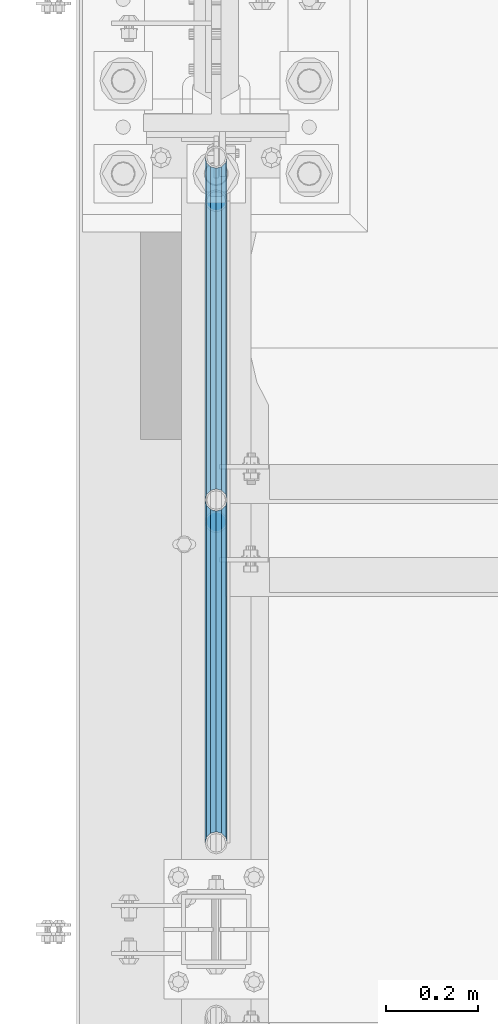
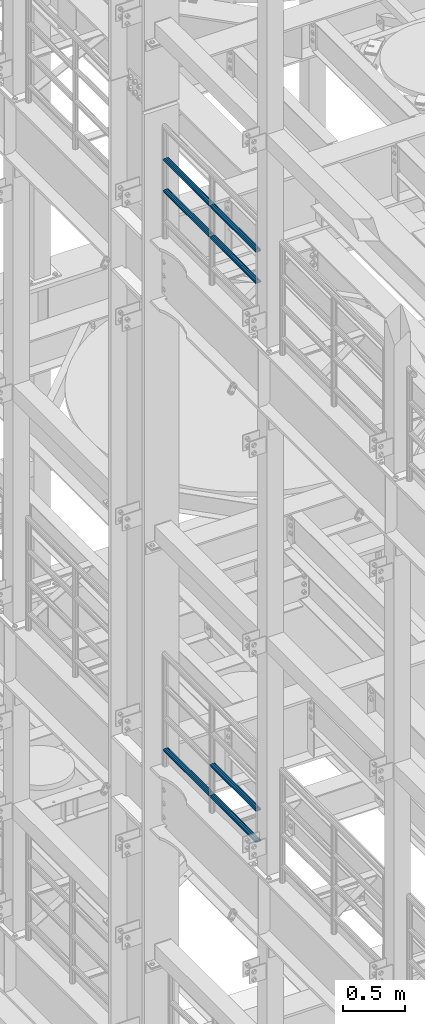
# One storey, part 1284 of 1876: 7 beams, 2 elements without a shape of their own.
"""IFC2X3 building model written with IfcOpenShell, lengths in millimetres."""

from ifc_helpers import new_model, si_unit, frame, origin_with_axes, place, context, subcontext, project, spatial, faceted_brep, material, type_object, element, aggregate, save


model = new_model("IFC2X3")

# Units and contexts
model_context = context("Model", 3, precision=1e-05, world=origin_with_axes())
body_context = subcontext(model_context, "Body", "Model", "MODEL_VIEW")
ifc_project = project(units=[si_unit("LENGTHUNIT", "METRE", prefix="MILLI"), si_unit("AREAUNIT", "SQUARE_METRE"), si_unit("VOLUMEUNIT", "CUBIC_METRE"), si_unit("MASSUNIT", "GRAM", prefix="KILO"), si_unit("TIMEUNIT", "SECOND"), si_unit("PLANEANGLEUNIT", "RADIAN"), si_unit("SOLIDANGLEUNIT", "STERADIAN"), si_unit("THERMODYNAMICTEMPERATUREUNIT", "DEGREE_CELSIUS"), si_unit("LUMINOUSINTENSITYUNIT", "LUMEN")], contexts=[model_context])

# Site, building, storey
site_placement = place(None, origin_with_axes())
site = spatial("IfcSite", under=ifc_project, at=site_placement, CompositionType="ELEMENT")
building_placement = place(site_placement, origin_with_axes())
building = spatial("IfcBuilding", under=site, at=building_placement, Name="Undefined", CompositionType="ELEMENT")
storey_placement = place(building_placement, origin_with_axes())
storey = spatial("IfcBuildingStorey", under=building, at=storey_placement, Name="Undefined", CompositionType="ELEMENT", Elevation=0.0)

# Assembly, beams
assembly_1_placement = place(storey_placement, origin_with_axes())
assembly_1 = element("IfcElementAssembly", 1, at=assembly_1_placement, inside=storey, Name="RAIL", AssemblyPlace="NOTDEFINED", PredefinedType="RIGID_FRAME")
ifc_material = material()
beam_type = type_object("IfcBeamType", Name="PIPE1-1/2SCH40", PredefinedType="NOTDEFINED")
beam_1_placement = place(assembly_1_placement, frame((-1.81898940354586e-12, 5777.23, 13776.325), z_axis=(0.0, 0.0, -1.0), x_axis=(0.0, 1.0, 0.0)))
beam_1 = element("IfcBeam", 2, at=beam_1_placement, type_object=beam_type, material=ifc_material, Name="RAIL", ObjectType="PIPE1-1/2SCH40", context=body_context, shape_type="Brep", body=[
    faceted_brep([(0.0, 24.1299999999992, 0.0), (12.0650000000064, 20.8971929933177, -12.0649999999987), (12.0650000000064, 20.8971929933177, 12.0649999999987), (12.0650000000064, -20.8971929933177, 12.0649999999987), (12.0650000000064, -20.8971929933177, -12.0649999999987), (0.0, -24.1299999999992, 0.0), (20.8971929933249, -12.0650000000005, 20.8971929933177), (20.8971929933249, -12.0650000000005, 15.8661214311796), (15.2545715621445, -17.7076214311801, 10.2235000000001), (12.5151929933249, -20.4470000000001, 0.0), (15.2545715621445, -17.7076214311801, -10.2235000000001), (20.8971929933249, -12.0650000000005, -15.8661214311796), (20.8971929933249, -12.0650000000005, -20.8971929933177), (24.1300000000063, 0.0, -20.4470000000001), (24.1300000000063, 0.0, -24.130000000001), (21.3906214311868, -10.2235000000001, -17.7076214311819), (21.3906214311868, 10.2235000000001, -17.7076214311819), (20.8971929933249, 12.0650000000005, -15.8661214311796), (20.8971929933249, 12.0650000000005, -20.8971929933177), (15.2545715621445, 17.7076214311801, -10.2235000000001), (12.5151929933249, 20.4470000000001, 0.0), (15.2545715621445, 17.7076214311801, 10.2235000000001), (20.8971929933249, 12.0650000000005, 15.8661214311796), (20.8971929933249, 12.0650000000005, 20.8971929933177), (21.3906214311868, 10.2235000000001, 17.7076214311819), (24.1300000000064, 0.0, 20.4470000000001), (24.1300000000064, 0.0, 24.130000000001), (21.3906214311868, -10.2235000000001, 17.7076214311819), (748.982500000002, 24.1300000000001, 0.0), (736.917500000002, 20.8971929933186, -12.0649999999987), (728.085307006683, 12.0649999999996, -20.8971929933177), (748.982500000002, -24.1300000000001, 0.0), (736.917500000002, -20.8971929933186, -12.0649999999987), (736.917500000002, -20.8971929933186, 12.0649999999987), (728.085307006683, -12.0649999999996, 20.8971929933177), (728.085307006683, -12.0649999999996, -20.8971929933177), (724.852500000002, 0.0, -24.130000000001), (727.591878568821, 10.2235000000001, -17.7076214311819), (724.852500000002, 0.0, -20.4470000000001), (728.085307006683, 12.0649999999996, -15.8661214311796), (728.085307006683, -12.0649999999996, -15.8661214311796), (727.591878568821, -10.2235000000001, -17.7076214311819), (733.727928437864, -17.7076214311801, -10.2235000000001), (736.467307006683, -20.4470000000001, 0.0), (733.727928437864, -17.7076214311801, 10.2235000000001), (728.085307006683, -12.0649999999996, 15.8661214311796), (727.591878568821, -10.2235000000001, 17.7076214311819), (724.852500000002, 0.0, 20.4470000000001), (724.852500000002, 0.0, 24.130000000001), (728.085307006683, 12.0649999999996, 20.8971929933177), (736.917500000002, 20.8971929933186, 12.0649999999987), (728.085307006683, 12.0649999999996, 15.8661214311796), (733.727928437864, 17.7076214311801, 10.2235000000001), (736.467307006683, 20.4470000000001, 0.0), (733.727928437864, 17.7076214311801, -10.2235000000001), (727.591878568821, 10.2235000000001, 17.7076214311819)], [[[0, 1, 2]], [[3, 4, 5]], [[6, 7, 8, 9, 10, 11, 12, 4, 3]], [[13, 14, 12, 11, 15]], [[16, 17, 18, 14, 13]], [[2, 1, 18, 17, 19, 20, 21, 22, 23]], [[23, 22, 24, 25, 26]], [[26, 25, 27, 7, 6]], [[1, 0, 28, 29]], [[18, 1, 29, 30]], [[31, 32, 33]], [[6, 3, 33, 34]], [[3, 5, 31, 33]], [[5, 4, 32, 31]], [[4, 12, 35, 32]], [[12, 14, 36, 35]], [[14, 18, 30, 36]], [[37, 38, 36, 30, 39]], [[40, 35, 36, 38, 41]], [[33, 32, 35, 40, 42, 43, 44, 45, 34]], [[34, 45, 46, 47, 48]], [[26, 6, 34, 48]], [[2, 23, 49, 50]], [[23, 26, 48, 49]], [[0, 2, 50, 28]], [[28, 50, 29]], [[49, 51, 52, 53, 54, 39, 30, 29, 50]], [[48, 47, 55, 51, 49]], [[25, 24, 55, 47]], [[55, 24, 22, 21, 52, 51]], [[21, 20, 53, 52]], [[20, 19, 54, 53]], [[19, 17, 16, 37, 39, 54]], [[16, 13, 38, 37]], [[13, 15, 41, 38]], [[41, 15, 11, 10, 42, 40]], [[10, 9, 43, 42]], [[9, 8, 44, 43]], [[8, 7, 27, 46, 45, 44]], [[27, 25, 47, 46]]]),
])
beam_2_placement = place(assembly_1_placement, frame((-1.81898940354586e-12, 6526.2125, 13776.325), z_axis=(0.0, 0.0, -1.0), x_axis=(0.0, 1.0, 0.0)))
beam_2 = element("IfcBeam", 3, at=beam_2_placement, type_object=beam_type, material=ifc_material, Name="RAIL", ObjectType="PIPE1-1/2SCH40", context=body_context, shape_type="Brep", body=[
    faceted_brep([(0.0, 24.1299999999992, 0.0), (12.0650000000064, 20.8971929933177, -12.0649999999987), (12.0650000000064, 20.8971929933177, 12.0649999999987), (12.0650000000064, -20.8971929933177, 12.0649999999987), (12.0650000000064, -20.8971929933177, -12.0649999999987), (0.0, -24.1299999999992, 0.0), (20.8971929933249, -12.0650000000005, 20.8971929933177), (20.8971929933249, -12.0650000000005, 15.8661214311796), (15.2545715621445, -17.7076214311801, 10.2235000000001), (12.5151929933249, -20.4470000000001, 0.0), (15.2545715621445, -17.7076214311801, -10.2235000000001), (20.8971929933249, -12.0650000000005, -15.8661214311796), (20.8971929933249, -12.0650000000005, -20.8971929933177), (24.1300000000063, 0.0, -20.4470000000001), (24.1300000000063, 0.0, -24.130000000001), (21.3906214311868, -10.2235000000001, -17.7076214311819), (21.3906214311868, 10.2235000000001, -17.7076214311819), (20.8971929933249, 12.0650000000005, -15.8661214311796), (20.8971929933249, 12.0650000000005, -20.8971929933177), (15.2545715621445, 17.7076214311801, -10.2235000000001), (12.5151929933249, 20.4470000000001, 0.0), (15.2545715621445, 17.7076214311801, 10.2235000000001), (20.8971929933249, 12.0650000000005, 15.8661214311796), (20.8971929933249, 12.0650000000005, 20.8971929933177), (21.3906214311868, 10.2235000000001, 17.7076214311819), (24.1300000000064, 0.0, 20.4470000000001), (24.1300000000064, 0.0, 24.130000000001), (21.3906214311868, -10.2235000000001, 17.7076214311819), (748.982500000002, 24.1300000000001, 0.0), (736.917500000002, 20.8971929933186, -12.0649999999987), (728.085307006683, 12.0649999999996, -20.8971929933177), (748.982500000002, -24.1300000000001, 0.0), (736.917500000002, -20.8971929933186, -12.0649999999987), (736.917500000002, -20.8971929933186, 12.0649999999987), (728.085307006683, -12.0649999999996, 20.8971929933177), (728.085307006683, -12.0649999999996, -20.8971929933177), (724.852500000002, 0.0, -24.130000000001), (727.591878568821, 10.2235000000001, -17.7076214311819), (724.852500000002, 0.0, -20.4470000000001), (728.085307006683, 12.0649999999996, -15.8661214311796), (728.085307006683, -12.0649999999996, -15.8661214311796), (727.591878568821, -10.2235000000001, -17.7076214311819), (733.727928437864, -17.7076214311801, -10.2235000000001), (736.467307006683, -20.4470000000001, 0.0), (733.727928437864, -17.7076214311801, 10.2235000000001), (728.085307006683, -12.0649999999996, 15.8661214311796), (727.591878568821, -10.2235000000001, 17.7076214311819), (724.852500000002, 0.0, 20.4470000000001), (724.852500000002, 0.0, 24.130000000001), (728.085307006683, 12.0649999999996, 20.8971929933177), (736.917500000002, 20.8971929933186, 12.0649999999987), (728.085307006683, 12.0649999999996, 15.8661214311796), (733.727928437864, 17.7076214311801, 10.2235000000001), (736.467307006683, 20.4470000000001, 0.0), (733.727928437864, 17.7076214311801, -10.2235000000001), (727.591878568821, 10.2235000000001, 17.7076214311819)], [[[0, 1, 2]], [[3, 4, 5]], [[6, 7, 8, 9, 10, 11, 12, 4, 3]], [[13, 14, 12, 11, 15]], [[16, 17, 18, 14, 13]], [[2, 1, 18, 17, 19, 20, 21, 22, 23]], [[23, 22, 24, 25, 26]], [[26, 25, 27, 7, 6]], [[1, 0, 28, 29]], [[18, 1, 29, 30]], [[31, 32, 33]], [[6, 3, 33, 34]], [[3, 5, 31, 33]], [[5, 4, 32, 31]], [[4, 12, 35, 32]], [[12, 14, 36, 35]], [[14, 18, 30, 36]], [[37, 38, 36, 30, 39]], [[40, 35, 36, 38, 41]], [[33, 32, 35, 40, 42, 43, 44, 45, 34]], [[34, 45, 46, 47, 48]], [[26, 6, 34, 48]], [[2, 23, 49, 50]], [[23, 26, 48, 49]], [[0, 2, 50, 28]], [[28, 50, 29]], [[49, 51, 52, 53, 54, 39, 30, 29, 50]], [[48, 47, 55, 51, 49]], [[25, 24, 55, 47]], [[55, 24, 22, 21, 52, 51]], [[21, 20, 53, 52]], [[20, 19, 54, 53]], [[19, 17, 16, 37, 39, 54]], [[16, 13, 38, 37]], [[13, 15, 41, 38]], [[41, 15, 11, 10, 42, 40]], [[10, 9, 43, 42]], [[9, 8, 44, 43]], [[8, 7, 27, 46, 45, 44]], [[27, 25, 47, 46]]]),
])
beam_3_placement = place(assembly_1_placement, frame((-1.81898940354586e-12, 5777.23, 14081.125), z_axis=(0.0, 0.0, -1.0), x_axis=(0.0, 1.0, 0.0)))
beam_3 = element("IfcBeam", 4, at=beam_3_placement, type_object=beam_type, material=ifc_material, Name="RAIL", ObjectType="PIPE1-1/2SCH40", context=body_context, shape_type="Brep", body=[
    faceted_brep([(0.0, 24.1299999999992, 0.0), (12.0650000000064, 20.8971929933177, -12.0649999999987), (12.0650000000064, 20.8971929933177, 12.0649999999987), (12.0650000000064, -20.8971929933177, 12.0649999999987), (12.0650000000064, -20.8971929933177, -12.0649999999987), (0.0, -24.1299999999992, 0.0), (20.8971929933249, -12.0650000000005, 20.8971929933177), (20.8971929933249, -12.0650000000005, 15.8661214311796), (15.2545715621445, -17.7076214311801, 10.2235000000001), (12.5151929933249, -20.4470000000001, 0.0), (15.2545715621445, -17.7076214311801, -10.2235000000001), (20.8971929933249, -12.0650000000005, -15.8661214311796), (20.8971929933249, -12.0650000000005, -20.8971929933177), (24.1300000000063, 0.0, -20.4470000000001), (24.1300000000063, 0.0, -24.130000000001), (21.3906214311868, -10.2235000000001, -17.7076214311819), (21.3906214311868, 10.2235000000001, -17.7076214311819), (20.8971929933249, 12.0650000000005, -15.8661214311796), (20.8971929933249, 12.0650000000005, -20.8971929933177), (15.2545715621445, 17.7076214311801, -10.2235000000001), (12.5151929933249, 20.4470000000001, 0.0), (15.2545715621445, 17.7076214311801, 10.2235000000001), (20.8971929933249, 12.0650000000005, 15.8661214311796), (20.8971929933249, 12.0650000000005, 20.8971929933177), (21.3906214311868, 10.2235000000001, 17.7076214311819), (24.1300000000064, 0.0, 20.4470000000001), (24.1300000000064, 0.0, 24.130000000001), (21.3906214311868, -10.2235000000001, 17.7076214311819), (748.982500000002, 24.1300000000001, 0.0), (736.917500000002, 20.8971929933186, -12.0649999999987), (728.085307006683, 12.0649999999996, -20.8971929933177), (748.982500000002, -24.1300000000001, 0.0), (736.917500000002, -20.8971929933186, -12.0649999999987), (736.917500000002, -20.8971929933186, 12.0649999999987), (728.085307006683, -12.0649999999996, 20.8971929933177), (728.085307006683, -12.0649999999996, -20.8971929933177), (724.852500000002, 0.0, -24.130000000001), (727.591878568821, 10.2235000000001, -17.7076214311819), (724.852500000002, 0.0, -20.4470000000001), (728.085307006683, 12.0649999999996, -15.8661214311796), (728.085307006683, -12.0649999999996, -15.8661214311796), (727.591878568821, -10.2235000000001, -17.7076214311819), (733.727928437864, -17.7076214311801, -10.2235000000001), (736.467307006683, -20.4470000000001, 0.0), (733.727928437864, -17.7076214311801, 10.2235000000001), (728.085307006683, -12.0649999999996, 15.8661214311796), (727.591878568821, -10.2235000000001, 17.7076214311819), (724.852500000002, 0.0, 20.4470000000001), (724.852500000002, 0.0, 24.130000000001), (728.085307006683, 12.0649999999996, 20.8971929933177), (736.917500000002, 20.8971929933186, 12.0649999999987), (728.085307006683, 12.0649999999996, 15.8661214311796), (733.727928437864, 17.7076214311801, 10.2235000000001), (736.467307006683, 20.4470000000001, 0.0), (733.727928437864, 17.7076214311801, -10.2235000000001), (727.591878568821, 10.2235000000001, 17.7076214311819)], [[[0, 1, 2]], [[3, 4, 5]], [[6, 7, 8, 9, 10, 11, 12, 4, 3]], [[13, 14, 12, 11, 15]], [[16, 17, 18, 14, 13]], [[2, 1, 18, 17, 19, 20, 21, 22, 23]], [[23, 22, 24, 25, 26]], [[26, 25, 27, 7, 6]], [[1, 0, 28, 29]], [[18, 1, 29, 30]], [[31, 32, 33]], [[6, 3, 33, 34]], [[3, 5, 31, 33]], [[5, 4, 32, 31]], [[4, 12, 35, 32]], [[12, 14, 36, 35]], [[14, 18, 30, 36]], [[37, 38, 36, 30, 39]], [[40, 35, 36, 38, 41]], [[33, 32, 35, 40, 42, 43, 44, 45, 34]], [[34, 45, 46, 47, 48]], [[26, 6, 34, 48]], [[2, 23, 49, 50]], [[23, 26, 48, 49]], [[0, 2, 50, 28]], [[28, 50, 29]], [[49, 51, 52, 53, 54, 39, 30, 29, 50]], [[48, 47, 55, 51, 49]], [[25, 24, 55, 47]], [[55, 24, 22, 21, 52, 51]], [[21, 20, 53, 52]], [[20, 19, 54, 53]], [[19, 17, 16, 37, 39, 54]], [[16, 13, 38, 37]], [[13, 15, 41, 38]], [[41, 15, 11, 10, 42, 40]], [[10, 9, 43, 42]], [[9, 8, 44, 43]], [[8, 7, 27, 46, 45, 44]], [[27, 25, 47, 46]]]),
])
beam_4_placement = place(assembly_1_placement, frame((-1.81898940354586e-12, 6526.2125, 14081.125), z_axis=(0.0, 0.0, -1.0), x_axis=(0.0, 1.0, 0.0)))
beam_4 = element("IfcBeam", 5, at=beam_4_placement, type_object=beam_type, material=ifc_material, Name="RAIL", ObjectType="PIPE1-1/2SCH40", context=body_context, shape_type="Brep", body=[
    faceted_brep([(0.0, 24.1299999999992, 0.0), (12.0650000000064, 20.8971929933177, -12.0649999999987), (12.0650000000064, 20.8971929933177, 12.0649999999987), (12.0650000000064, -20.8971929933177, 12.0649999999987), (12.0650000000064, -20.8971929933177, -12.0649999999987), (0.0, -24.1299999999992, 0.0), (20.8971929933249, -12.0650000000005, 20.8971929933177), (20.8971929933249, -12.0650000000005, 15.8661214311796), (15.2545715621445, -17.7076214311801, 10.2235000000001), (12.5151929933249, -20.4470000000001, 0.0), (15.2545715621445, -17.7076214311801, -10.2235000000001), (20.8971929933249, -12.0650000000005, -15.8661214311796), (20.8971929933249, -12.0650000000005, -20.8971929933177), (24.1300000000063, 0.0, -20.4470000000001), (24.1300000000063, 0.0, -24.130000000001), (21.3906214311868, -10.2235000000001, -17.7076214311819), (21.3906214311868, 10.2235000000001, -17.7076214311819), (20.8971929933249, 12.0650000000005, -15.8661214311796), (20.8971929933249, 12.0650000000005, -20.8971929933177), (15.2545715621445, 17.7076214311801, -10.2235000000001), (12.5151929933249, 20.4470000000001, 0.0), (15.2545715621445, 17.7076214311801, 10.2235000000001), (20.8971929933249, 12.0650000000005, 15.8661214311796), (20.8971929933249, 12.0650000000005, 20.8971929933177), (21.3906214311868, 10.2235000000001, 17.7076214311819), (24.1300000000064, 0.0, 20.4470000000001), (24.1300000000064, 0.0, 24.130000000001), (21.3906214311868, -10.2235000000001, 17.7076214311819), (748.982500000002, 24.1300000000001, 0.0), (736.917500000002, 20.8971929933186, -12.0649999999987), (728.085307006683, 12.0649999999996, -20.8971929933177), (748.982500000002, -24.1300000000001, 0.0), (736.917500000002, -20.8971929933186, -12.0649999999987), (736.917500000002, -20.8971929933186, 12.0649999999987), (728.085307006683, -12.0649999999996, 20.8971929933177), (728.085307006683, -12.0649999999996, -20.8971929933177), (724.852500000002, 0.0, -24.130000000001), (727.591878568821, 10.2235000000001, -17.7076214311819), (724.852500000002, 0.0, -20.4470000000001), (728.085307006683, 12.0649999999996, -15.8661214311796), (728.085307006683, -12.0649999999996, -15.8661214311796), (727.591878568821, -10.2235000000001, -17.7076214311819), (733.727928437864, -17.7076214311801, -10.2235000000001), (736.467307006683, -20.4470000000001, 0.0), (733.727928437864, -17.7076214311801, 10.2235000000001), (728.085307006683, -12.0649999999996, 15.8661214311796), (727.591878568821, -10.2235000000001, 17.7076214311819), (724.852500000002, 0.0, 20.4470000000001), (724.852500000002, 0.0, 24.130000000001), (728.085307006683, 12.0649999999996, 20.8971929933177), (736.917500000002, 20.8971929933186, 12.0649999999987), (728.085307006683, 12.0649999999996, 15.8661214311796), (733.727928437864, 17.7076214311801, 10.2235000000001), (736.467307006683, 20.4470000000001, 0.0), (733.727928437864, 17.7076214311801, -10.2235000000001), (727.591878568821, 10.2235000000001, 17.7076214311819)], [[[0, 1, 2]], [[3, 4, 5]], [[6, 7, 8, 9, 10, 11, 12, 4, 3]], [[13, 14, 12, 11, 15]], [[16, 17, 18, 14, 13]], [[2, 1, 18, 17, 19, 20, 21, 22, 23]], [[23, 22, 24, 25, 26]], [[26, 25, 27, 7, 6]], [[1, 0, 28, 29]], [[18, 1, 29, 30]], [[31, 32, 33]], [[6, 3, 33, 34]], [[3, 5, 31, 33]], [[5, 4, 32, 31]], [[4, 12, 35, 32]], [[12, 14, 36, 35]], [[14, 18, 30, 36]], [[37, 38, 36, 30, 39]], [[40, 35, 36, 38, 41]], [[33, 32, 35, 40, 42, 43, 44, 45, 34]], [[34, 45, 46, 47, 48]], [[26, 6, 34, 48]], [[2, 23, 49, 50]], [[23, 26, 48, 49]], [[0, 2, 50, 28]], [[28, 50, 29]], [[49, 51, 52, 53, 54, 39, 30, 29, 50]], [[48, 47, 55, 51, 49]], [[25, 24, 55, 47]], [[55, 24, 22, 21, 52, 51]], [[21, 20, 53, 52]], [[20, 19, 54, 53]], [[19, 17, 16, 37, 39, 54]], [[16, 13, 38, 37]], [[13, 15, 41, 38]], [[41, 15, 11, 10, 42, 40]], [[10, 9, 43, 42]], [[9, 8, 44, 43]], [[8, 7, 27, 46, 45, 44]], [[27, 25, 47, 46]]]),
])
aggregate(assembly_1, [beam_1, beam_2, beam_3, beam_4])

assembly_2_placement = place(storey_placement, origin_with_axes())
assembly_2 = element("IfcElementAssembly", 6, at=assembly_2_placement, inside=storey, Name="RAIL", AssemblyPlace="NOTDEFINED", PredefinedType="RIGID_FRAME")
beam_5_placement = place(assembly_2_placement, frame((-1.81898940354586e-12, 6526.2125, 8315.325), z_axis=(0.0, 0.0, 1.0), x_axis=(0.0, -1.0, 0.0)))
beam_5 = element("IfcBeam", 7, at=beam_5_placement, type_object=beam_type, material=ifc_material, Name="RAIL", ObjectType="PIPE1-1/2SCH40", context=body_context, shape_type="Brep", body=[
    faceted_brep([(728.085307006683, -12.0649999999996, 20.8971929933177), (728.085307006683, -12.0649999999996, 15.8661214311796), (727.591878568821, -10.2235000000001, 17.7076214311819), (724.852500000002, 0.0, 20.4470000000001), (724.852500000002, 0.0, 24.130000000001), (727.591878568821, 10.2235000000001, 17.7076214311819), (728.085307006683, 12.0649999999996, 15.8661214311796), (728.085307006683, 12.0649999999996, 20.8971929933177), (748.982500000002, 24.1300000000001, 0.0), (736.917500000002, 20.8971929933186, 12.0649999999987), (736.917500000002, 20.8971929933186, -12.0649999999987), (733.727928437864, 17.7076214311801, 10.2235000000001), (736.467307006683, 20.4470000000001, 0.0), (733.727928437864, 17.7076214311801, -10.2235000000001), (728.085307006683, 12.0649999999996, -15.8661214311796), (728.085307006683, 12.0649999999996, -20.8971929933177), (727.591878568821, 10.2235000000001, -17.7076214311819), (724.852500000002, 0.0, -20.4470000000001), (724.852500000002, 0.0, -24.130000000001), (728.085307006683, -12.0649999999996, -15.8661214311796), (728.085307006683, -12.0649999999996, -20.8971929933177), (727.591878568821, -10.2235000000001, -17.7076214311819), (748.982500000002, -24.1300000000001, 0.0), (736.917500000002, -20.8971929933186, -12.0649999999987), (736.917500000002, -20.8971929933186, 12.0649999999987), (733.727928437864, -17.7076214311801, -10.2235000000001), (736.467307006683, -20.4470000000001, 0.0), (733.727928437864, -17.7076214311801, 10.2235000000001), (12.0650000000064, -20.8971929933177, -12.0649999999987), (20.8971929933249, -12.0650000000005, -20.8971929933177), (0.0, 24.1299999999992, 0.0), (12.0650000000064, 20.8971929933177, -12.0649999999987), (12.0650000000064, 20.8971929933177, 12.0649999999987), (20.8971929933249, 12.0650000000005, 20.8971929933177), (24.1300000000064, 0.0, 24.130000000001), (20.8971929933249, 12.0650000000005, -20.8971929933177), (24.1300000000063, 0.0, -24.130000000001), (24.1300000000063, 0.0, -20.4470000000001), (20.8971929933249, -12.0650000000005, -15.8661214311796), (21.3906214311868, -10.2235000000001, -17.7076214311819), (21.3906214311868, 10.2235000000001, -17.7076214311819), (20.8971929933249, 12.0650000000005, -15.8661214311796), (15.2545715621445, 17.7076214311801, -10.2235000000001), (12.5151929933249, 20.4470000000001, 0.0), (15.2545715621445, 17.7076214311801, 10.2235000000001), (20.8971929933249, 12.0650000000005, 15.8661214311796), (21.3906214311868, 10.2235000000001, 17.7076214311819), (24.1300000000064, 0.0, 20.4470000000001), (21.3906214311868, -10.2235000000001, 17.7076214311819), (20.8971929933249, -12.0650000000005, 15.8661214311796), (20.8971929933249, -12.0650000000005, 20.8971929933177), (12.0650000000064, -20.8971929933177, 12.0649999999987), (0.0, -24.1299999999992, 0.0), (15.2545715621445, -17.7076214311801, 10.2235000000001), (12.5151929933249, -20.4470000000001, 0.0), (15.2545715621445, -17.7076214311801, -10.2235000000001)], [[[0, 1, 2, 3, 4]], [[4, 3, 5, 6, 7]], [[8, 9, 10]], [[7, 6, 11, 12, 13, 14, 15, 10, 9]], [[16, 17, 18, 15, 14]], [[19, 20, 18, 17, 21]], [[22, 23, 24]], [[24, 23, 20, 19, 25, 26, 27, 1, 0]], [[28, 29, 20, 23]], [[30, 31, 32]], [[33, 34, 4, 7]], [[32, 33, 7, 9]], [[30, 32, 9, 8]], [[31, 30, 8, 10]], [[35, 31, 10, 15]], [[36, 35, 15, 18]], [[29, 36, 18, 20]], [[37, 36, 29, 38, 39]], [[40, 41, 35, 36, 37]], [[32, 31, 35, 41, 42, 43, 44, 45, 33]], [[33, 45, 46, 47, 34]], [[34, 47, 48, 49, 50]], [[34, 50, 0, 4]], [[50, 51, 24, 0]], [[51, 52, 22, 24]], [[52, 28, 23, 22]], [[51, 28, 52]], [[50, 49, 53, 54, 55, 38, 29, 28, 51]], [[55, 54, 26, 25]], [[21, 39, 38, 55, 25, 19]], [[37, 39, 21, 17]], [[40, 37, 17, 16]], [[42, 41, 40, 16, 14, 13]], [[43, 42, 13, 12]], [[44, 43, 12, 11]], [[5, 46, 45, 44, 11, 6]], [[47, 46, 5, 3]], [[48, 47, 3, 2]], [[53, 49, 48, 2, 1, 27]], [[54, 53, 27, 26]]]),
])
beam_6_placement = place(assembly_2_placement, frame((-1.14353341410584e-11, 7275.195, 8315.325), z_axis=(0.0, 0.0, 1.0), x_axis=(0.0, -1.0, 0.0)))
beam_6 = element("IfcBeam", 8, at=beam_6_placement, type_object=beam_type, material=ifc_material, Name="RAIL", ObjectType="PIPE1-1/2SCH40", context=body_context, shape_type="Brep", body=[
    faceted_brep([(728.085307006683, -12.0649999999996, 20.8971929933177), (728.085307006683, -12.0649999999996, 15.8661214311796), (727.591878568821, -10.2235000000001, 17.7076214311819), (724.852500000002, 0.0, 20.4470000000001), (724.852500000002, 0.0, 24.130000000001), (727.591878568821, 10.2235000000001, 17.7076214311819), (728.085307006683, 12.0649999999996, 15.8661214311796), (728.085307006683, 12.0649999999996, 20.8971929933177), (748.982500000002, 24.1300000000001, 0.0), (736.917500000002, 20.8971929933186, 12.0649999999987), (736.917500000002, 20.8971929933186, -12.0649999999987), (733.727928437864, 17.7076214311801, 10.2235000000001), (736.467307006683, 20.4470000000001, 0.0), (733.727928437864, 17.7076214311801, -10.2235000000001), (728.085307006683, 12.0649999999996, -15.8661214311796), (728.085307006683, 12.0649999999996, -20.8971929933177), (727.591878568821, 10.2235000000001, -17.7076214311819), (724.852500000002, 0.0, -20.4470000000001), (724.852500000002, 0.0, -24.130000000001), (728.085307006683, -12.0649999999996, -15.8661214311796), (728.085307006683, -12.0649999999996, -20.8971929933177), (727.591878568821, -10.2235000000001, -17.7076214311819), (748.982500000002, -24.1300000000001, 0.0), (736.917500000002, -20.8971929933186, -12.0649999999987), (736.917500000002, -20.8971929933186, 12.0649999999987), (733.727928437864, -17.7076214311801, -10.2235000000001), (736.467307006683, -20.4470000000001, 0.0), (733.727928437864, -17.7076214311801, 10.2235000000001), (12.0650000000064, -20.8971929933177, -12.0649999999987), (20.8971929933249, -12.0650000000005, -20.8971929933177), (0.0, 24.1299999999992, 0.0), (12.0650000000064, 20.8971929933177, -12.0649999999987), (12.0650000000064, 20.8971929933177, 12.0649999999987), (20.8971929933249, 12.0650000000005, 20.8971929933177), (24.1300000000064, 0.0, 24.130000000001), (20.8971929933249, 12.0650000000005, -20.8971929933177), (24.1300000000063, 0.0, -24.130000000001), (24.1300000000063, 0.0, -20.4470000000001), (20.8971929933249, -12.0650000000005, -15.8661214311796), (21.3906214311868, -10.2235000000001, -17.7076214311819), (21.3906214311868, 10.2235000000001, -17.7076214311819), (20.8971929933249, 12.0650000000005, -15.8661214311796), (15.2545715621445, 17.7076214311801, -10.2235000000001), (12.5151929933249, 20.4470000000001, 0.0), (15.2545715621445, 17.7076214311801, 10.2235000000001), (20.8971929933249, 12.0650000000005, 15.8661214311796), (21.3906214311868, 10.2235000000001, 17.7076214311819), (24.1300000000064, 0.0, 20.4470000000001), (21.3906214311868, -10.2235000000001, 17.7076214311819), (20.8971929933249, -12.0650000000005, 15.8661214311796), (20.8971929933249, -12.0650000000005, 20.8971929933177), (12.0650000000064, -20.8971929933177, 12.0649999999987), (0.0, -24.1299999999992, 0.0), (15.2545715621445, -17.7076214311801, 10.2235000000001), (12.5151929933249, -20.4470000000001, 0.0), (15.2545715621445, -17.7076214311801, -10.2235000000001)], [[[0, 1, 2, 3, 4]], [[4, 3, 5, 6, 7]], [[8, 9, 10]], [[7, 6, 11, 12, 13, 14, 15, 10, 9]], [[16, 17, 18, 15, 14]], [[19, 20, 18, 17, 21]], [[22, 23, 24]], [[24, 23, 20, 19, 25, 26, 27, 1, 0]], [[28, 29, 20, 23]], [[30, 31, 32]], [[33, 34, 4, 7]], [[32, 33, 7, 9]], [[30, 32, 9, 8]], [[31, 30, 8, 10]], [[35, 31, 10, 15]], [[36, 35, 15, 18]], [[29, 36, 18, 20]], [[37, 36, 29, 38, 39]], [[40, 41, 35, 36, 37]], [[32, 31, 35, 41, 42, 43, 44, 45, 33]], [[33, 45, 46, 47, 34]], [[34, 47, 48, 49, 50]], [[34, 50, 0, 4]], [[50, 51, 24, 0]], [[51, 52, 22, 24]], [[52, 28, 23, 22]], [[51, 28, 52]], [[50, 49, 53, 54, 55, 38, 29, 28, 51]], [[55, 54, 26, 25]], [[21, 39, 38, 55, 25, 19]], [[37, 39, 21, 17]], [[40, 37, 17, 16]], [[42, 41, 40, 16, 14, 13]], [[43, 42, 13, 12]], [[44, 43, 12, 11]], [[5, 46, 45, 44, 11, 6]], [[47, 46, 5, 3]], [[48, 47, 3, 2]], [[53, 49, 48, 2, 1, 27]], [[54, 53, 27, 26]]]),
])
beam_7_placement = place(assembly_2_placement, frame((-1.81898940354586e-12, 5777.23, 8620.125), z_axis=(0.0, 0.0, -1.0), x_axis=(0.0, 1.0, 0.0)))
beam_7 = element("IfcBeam", 9, at=beam_7_placement, type_object=beam_type, material=ifc_material, Name="RAIL", ObjectType="PIPE1-1/2SCH40", context=body_context, shape_type="Brep", body=[
    faceted_brep([(0.0, 24.1299999999992, 0.0), (12.0650000000064, 20.8971929933177, -12.0649999999987), (12.0650000000064, 20.8971929933177, 12.0649999999987), (12.0650000000064, -20.8971929933177, 12.0649999999987), (12.0650000000064, -20.8971929933177, -12.0649999999987), (0.0, -24.1299999999992, 0.0), (20.8971929933249, -12.0650000000005, 20.8971929933177), (20.8971929933249, -12.0650000000005, 15.8661214311796), (15.2545715621445, -17.7076214311801, 10.2235000000001), (12.5151929933249, -20.4470000000001, 0.0), (15.2545715621445, -17.7076214311801, -10.2235000000001), (20.8971929933249, -12.0650000000005, -15.8661214311796), (20.8971929933249, -12.0650000000005, -20.8971929933177), (24.1300000000063, 0.0, -20.4470000000001), (24.1300000000063, 0.0, -24.130000000001), (21.3906214311868, -10.2235000000001, -17.7076214311819), (21.3906214311868, 10.2235000000001, -17.7076214311819), (20.8971929933249, 12.0650000000005, -15.8661214311796), (20.8971929933249, 12.0650000000005, -20.8971929933177), (15.2545715621445, 17.7076214311801, -10.2235000000001), (12.5151929933249, 20.4470000000001, 0.0), (15.2545715621445, 17.7076214311801, 10.2235000000001), (20.8971929933249, 12.0650000000005, 15.8661214311796), (20.8971929933249, 12.0650000000005, 20.8971929933177), (21.3906214311868, 10.2235000000001, 17.7076214311819), (24.1300000000064, 0.0, 20.4470000000001), (24.1300000000064, 0.0, 24.130000000001), (21.3906214311868, -10.2235000000001, 17.7076214311819), (748.982500000002, 24.1300000000001, 0.0), (736.917500000002, 20.8971929933186, -12.0649999999987), (728.085307006683, 12.0649999999996, -20.8971929933177), (748.982500000002, -24.1300000000001, 0.0), (736.917500000002, -20.8971929933186, -12.0649999999987), (736.917500000002, -20.8971929933186, 12.0649999999987), (728.085307006683, -12.0649999999996, 20.8971929933177), (728.085307006683, -12.0649999999996, -20.8971929933177), (724.852500000002, 0.0, -24.130000000001), (727.591878568821, 10.2235000000001, -17.7076214311819), (724.852500000002, 0.0, -20.4470000000001), (728.085307006683, 12.0649999999996, -15.8661214311796), (728.085307006683, -12.0649999999996, -15.8661214311796), (727.591878568821, -10.2235000000001, -17.7076214311819), (733.727928437864, -17.7076214311801, -10.2235000000001), (736.467307006683, -20.4470000000001, 0.0), (733.727928437864, -17.7076214311801, 10.2235000000001), (728.085307006683, -12.0649999999996, 15.8661214311796), (727.591878568821, -10.2235000000001, 17.7076214311819), (724.852500000002, 0.0, 20.4470000000001), (724.852500000002, 0.0, 24.130000000001), (728.085307006683, 12.0649999999996, 20.8971929933177), (736.917500000002, 20.8971929933186, 12.0649999999987), (728.085307006683, 12.0649999999996, 15.8661214311796), (733.727928437864, 17.7076214311801, 10.2235000000001), (736.467307006683, 20.4470000000001, 0.0), (733.727928437864, 17.7076214311801, -10.2235000000001), (727.591878568821, 10.2235000000001, 17.7076214311819)], [[[0, 1, 2]], [[3, 4, 5]], [[6, 7, 8, 9, 10, 11, 12, 4, 3]], [[13, 14, 12, 11, 15]], [[16, 17, 18, 14, 13]], [[2, 1, 18, 17, 19, 20, 21, 22, 23]], [[23, 22, 24, 25, 26]], [[26, 25, 27, 7, 6]], [[1, 0, 28, 29]], [[18, 1, 29, 30]], [[31, 32, 33]], [[6, 3, 33, 34]], [[3, 5, 31, 33]], [[5, 4, 32, 31]], [[4, 12, 35, 32]], [[12, 14, 36, 35]], [[14, 18, 30, 36]], [[37, 38, 36, 30, 39]], [[40, 35, 36, 38, 41]], [[33, 32, 35, 40, 42, 43, 44, 45, 34]], [[34, 45, 46, 47, 48]], [[26, 6, 34, 48]], [[2, 23, 49, 50]], [[23, 26, 48, 49]], [[0, 2, 50, 28]], [[28, 50, 29]], [[49, 51, 52, 53, 54, 39, 30, 29, 50]], [[48, 47, 55, 51, 49]], [[25, 24, 55, 47]], [[55, 24, 22, 21, 52, 51]], [[21, 20, 53, 52]], [[20, 19, 54, 53]], [[19, 17, 16, 37, 39, 54]], [[16, 13, 38, 37]], [[13, 15, 41, 38]], [[41, 15, 11, 10, 42, 40]], [[10, 9, 43, 42]], [[9, 8, 44, 43]], [[8, 7, 27, 46, 45, 44]], [[27, 25, 47, 46]]]),
])
aggregate(assembly_2, [beam_5, beam_6, beam_7])

save(model, "model.ifc")
